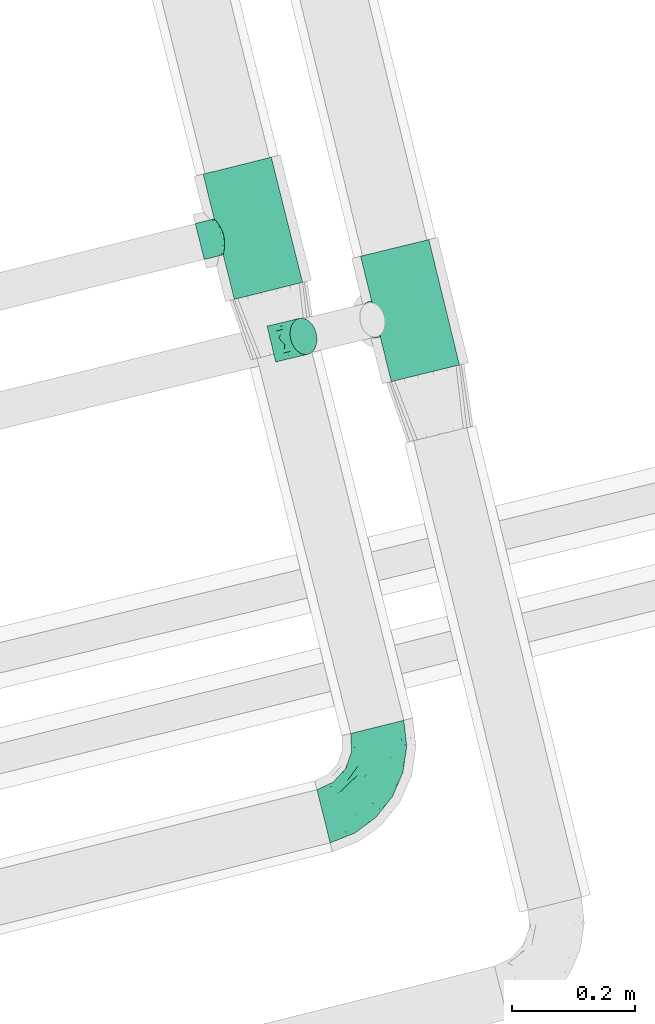
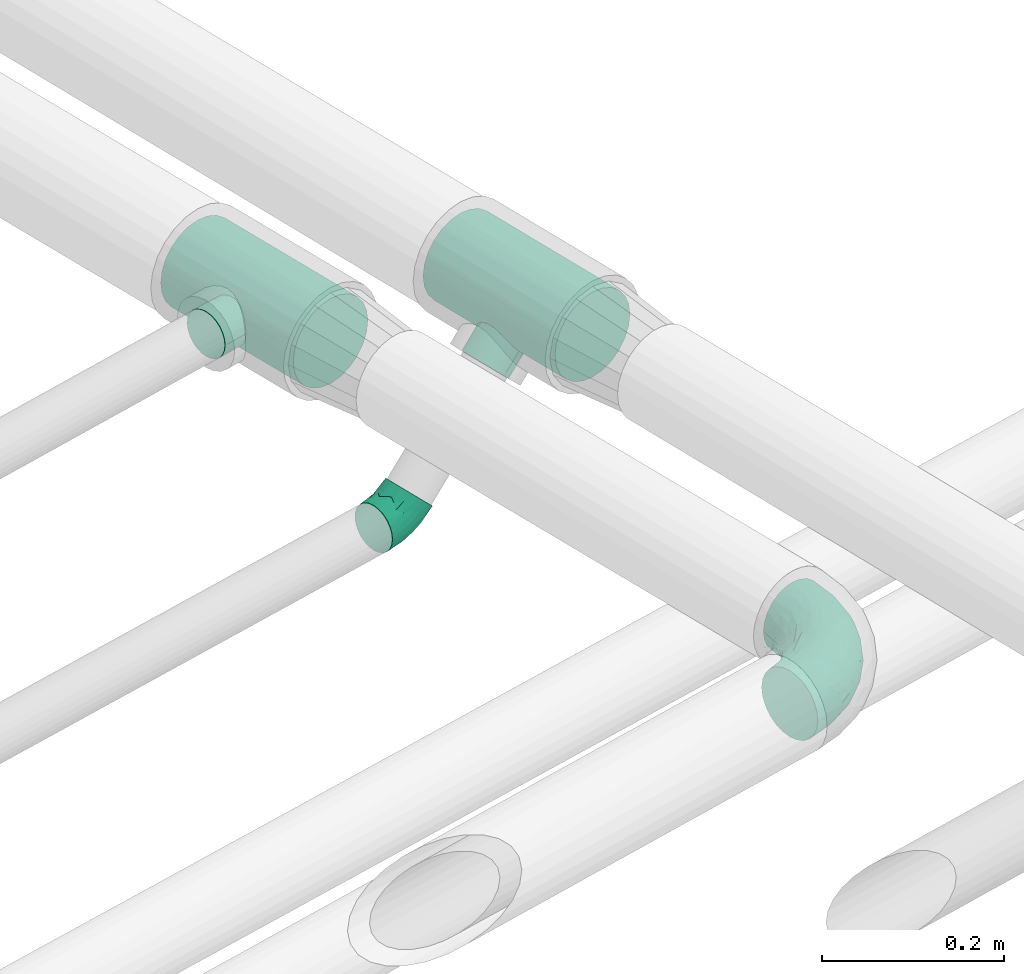
# One storey, part 83 of 93: 4 flow fittings.
"""IFC2X3 building model written with IfcOpenShell, lengths in millimetres."""

import ifcopenshell
import ifcopenshell.guid

model = None  # the IFC model being written
_history = None  # IfcOwnerHistory: only IFC2X3 demands one
_inside = {}  # id of a spatial element -> (the spatial element, [elements in it])
_under = {}  # id of a project, library or spatial element -> (it, [spatial elements below it])
_declared = {}  # id of a project -> (the project, [libraries it declares])
_typed = {}  # id of a type object -> (the type object, [elements of that type])
_made_of = {}  # id of a material, layer set ... -> (it, [elements and type objects made of it])


def new_model(schema):
    """Start an empty IFC model of exactly this schema.

    Asked for "IFC4X3", IfcOpenShell would pick the latest addendum, in which some entities
    have other attributes; the version numbers below select the first issue.
    IFC2X3 requires an IfcOwnerHistory on every rooted entity: one is made here for all.
    """
    global model, _history
    if schema == "IFC4X3":
        model = ifcopenshell.file(schema_version=(4, 3, 0, 0))
    else:
        model = ifcopenshell.file(schema=schema)
    _inside.clear()
    _under.clear()
    _declared.clear()
    _typed.clear()
    _made_of.clear()
    _history = None
    if model.schema == "IFC2X3":
        org = make("IfcOrganization", Name="unknown")
        user = make(
            "IfcPersonAndOrganization",
            ThePerson=make("IfcPerson", FamilyName="unknown"),
            TheOrganization=org,
        )
        app = make(
            "IfcApplication",
            ApplicationDeveloper=org,
            Version="unknown",
            ApplicationFullName="unknown",
            ApplicationIdentifier="unknown",
        )
        _history = make(
            "IfcOwnerHistory",
            OwningUser=user,
            OwningApplication=app,
            ChangeAction="ADDED",
            CreationDate=0,
        )
    return model


def make(cls, **values):
    """One entity of the class cls with the attributes given. An attribute that is None is left unset."""
    return model.create_entity(
        cls, **{name: value for name, value in values.items() if value is not None}
    )


def entity(cls, *values):
    """Any entity or typed value of the class cls, its attributes in the order of the schema. None: left unset."""
    e = model.create_entity(cls)
    for i, value in enumerate(values):
        if value is not None:
            e[i] = value
    return e


def rooted(cls, **values):
    """An entity with a GlobalId (a new one), such as an element, a storey or a relation."""
    return make(cls, GlobalId=ifcopenshell.guid.new(), OwnerHistory=_history, **values)


def si_unit(unit_type, name, prefix=None):
    """IfcSIUnit, for example si_unit("LENGTHUNIT", "METRE", prefix="MILLI")."""
    return make("IfcSIUnit", UnitType=unit_type, Prefix=prefix, Name=name)


def converted_unit(unit_type, name, factor, base, dimensions=None, offset=None):
    """IfcConversionBasedUnit, such as the inch: factor (a typed value) times the base unit."""
    return make(
        "IfcConversionBasedUnit"
        if offset is None
        else "IfcConversionBasedUnitWithOffset",
        ConversionOffset=offset,
        Dimensions=None
        if dimensions is None
        else entity("IfcDimensionalExponents", *dimensions),
        UnitType=unit_type,
        Name=name,
        ConversionFactor=make(
            "IfcMeasureWithUnit", ValueComponent=factor, UnitComponent=base
        ),
    )


def derived_unit(unit_type, elements):
    """IfcDerivedUnit: a product of units, each with its exponent."""
    return make(
        "IfcDerivedUnit",
        Elements=[
            make("IfcDerivedUnitElement", Unit=unit, Exponent=power)
            for unit, power in elements
        ],
        UnitType=unit_type,
    )


def assignment(units):
    """IfcUnitAssignment: the units of a project."""
    return None if units is None else make("IfcUnitAssignment", Units=units)


def point(xyz):
    """IfcCartesianPoint."""
    return None if xyz is None else make("IfcCartesianPoint", Coordinates=xyz)


def direction(xyz):
    """IfcDirection."""
    return None if xyz is None else make("IfcDirection", DirectionRatios=xyz)


def frame(location, z_axis=None, x_axis=None):
    """IfcAxis2Placement3D, a coordinate frame: its origin and axes. An axis left out is left unset."""
    return make(
        "IfcAxis2Placement3D",
        Location=point(location),
        Axis=direction(z_axis),
        RefDirection=direction(x_axis),
    )


def origin():
    """The frame at (0, 0, 0) with its axes left unset."""
    return frame((0.0, 0.0, 0.0))


def place(relative_to, where):
    """IfcLocalPlacement: puts the frame where relative to a parent placement (None: the world)."""
    return make(
        "IfcLocalPlacement", PlacementRelTo=relative_to, RelativePlacement=where
    )


def context(
    kind, dimensions, precision=None, world=None, true_north=None, identifier=None
):
    """IfcGeometricRepresentationContext, for example the 3D "Model" context."""
    return make(
        "IfcGeometricRepresentationContext",
        ContextIdentifier=identifier,
        ContextType=kind,
        CoordinateSpaceDimension=dimensions,
        Precision=precision,
        WorldCoordinateSystem=world,
        TrueNorth=true_north,
    )


def subcontext(parent, identifier, kind, view, scale=None):
    """IfcGeometricRepresentationSubContext, for example "Body" below "Model"."""
    return make(
        "IfcGeometricRepresentationSubContext",
        ContextIdentifier=identifier,
        ContextType=kind,
        ParentContext=parent,
        TargetScale=scale,
        TargetView=view,
    )


def project(units=None, contexts=None):
    """IfcProject with its units and contexts."""
    return rooted(
        "IfcProject",
        Name="project",
        RepresentationContexts=contexts,
        UnitsInContext=assignment(units),
    )


def spatial(cls, under=None, at=None, **own):
    """A site, building, storey or space (cls), placed at a placement, below another one or the project."""
    s = rooted(cls, ObjectPlacement=at, **own)
    if under is not None:
        _under.setdefault(under.id(), (under, []))[1].append(s)
    return s


def faces_of(points, faces, orient=None, outer=None):
    """IfcFace entities. A face is a list of loops; a loop is a list of indices into points, from 0.

    orient and outer hold one flag for each loop. By default every Orientation is true, the
    first loop of a face is its IfcFaceOuterBound and the others are IfcFaceBound.
    """
    made = []
    for i, loops in enumerate(faces):
        bounds = []
        for j, loop in enumerate(loops):
            is_outer = j == 0 if outer is None else outer[i][j]
            bounds.append(
                make(
                    "IfcFaceOuterBound" if is_outer else "IfcFaceBound",
                    Bound=make("IfcPolyLoop", Polygon=[points[k] for k in loop]),
                    Orientation=True if orient is None else orient[i][j],
                )
            )
        made.append(make("IfcFace", Bounds=bounds))
    return made


def faceted_brep(points, faces, orient=None, outer=None, voids=None):
    """IfcFacetedBrep: a solid bounded by flat faces; with voids (closed shells), ...WithVoids."""
    shared = [point(p) for p in points]
    hull = make("IfcClosedShell", CfsFaces=faces_of(shared, faces, orient, outer))
    if voids is None:
        return make("IfcFacetedBrep", Outer=hull)
    return make(
        "IfcFacetedBrepWithVoids",
        Outer=hull,
        Voids=[
            make(cls, CfsFaces=faces_of(shared, fs, o, b)) for cls, fs, o, b in voids
        ],
    )


def shape(context_of_items, identifier, shape_type, items):
    """IfcShapeRepresentation: the items that make up one representation, for example the "Body"."""
    return make(
        "IfcShapeRepresentation",
        ContextOfItems=context_of_items,
        RepresentationIdentifier=identifier,
        RepresentationType=shape_type,
        Items=items,
    )


def source(mapping_origin, context_of_items, identifier, shape_type, items):
    """IfcRepresentationMap: a shape defined once, which mapped items show again and again."""
    return make(
        "IfcRepresentationMap",
        MappingOrigin=mapping_origin,
        MappedRepresentation=shape(context_of_items, identifier, shape_type, items),
    )


def transform(
    local_origin,
    x_axis=None,
    y_axis=None,
    z_axis=None,
    scale=None,
    scale2=None,
    scale3=None,
    uniform=True,
):
    """IfcCartesianTransformationOperator3D, or its non-uniform kind. x_axis, y_axis, z_axis: its Axis1, 2, 3."""
    if uniform:
        return make(
            "IfcCartesianTransformationOperator3D",
            Axis1=direction(x_axis),
            Axis2=direction(y_axis),
            LocalOrigin=point(local_origin),
            Scale=scale,
            Axis3=direction(z_axis),
        )
    return make(
        "IfcCartesianTransformationOperator3DnonUniform",
        Axis1=direction(x_axis),
        Axis2=direction(y_axis),
        LocalOrigin=point(local_origin),
        Scale=scale,
        Axis3=direction(z_axis),
        Scale2=scale2,
        Scale3=scale3,
    )


def mapped(mapping_source, mapping_target):
    """IfcMappedItem: shows the shape of a source again, moved by a transform."""
    return make(
        "IfcMappedItem", MappingSource=mapping_source, MappingTarget=mapping_target
    )


def material(Name=None, Category=None):
    """IfcMaterial."""
    return make("IfcMaterial", Name=Name, Category=Category)


def made_of(thing, what):
    """Note that an element or type object is made of a material, layer set ...; save() writes the relation."""
    if what is not None:
        _made_of.setdefault(what.id(), (what, []))[1].append(thing)
    return thing


def type_object(cls, material=None, **own):
    """A type object (cls), such as IfcWallType, which elements share."""
    return made_of(rooted(cls, **own), material)


def type_shapes(of_type, sources):
    """Give a type object the sources (RepresentationMaps) that its elements show as mapped items."""
    of_type.RepresentationMaps = sources


def element(
    cls,
    number,
    at=None,
    inside=None,
    cuts=None,
    type_object=None,
    material=None,
    context=None,
    identifier="Body",
    shape_type=None,
    held_by="IfcProductDefinitionShape",
    body=None,
    shapes=None,
    **own,
):
    """One element of the class cls, such as IfcWall. Its Tag is "e" and its number.

    at: its placement. inside: the storey or other place that contains it. cuts: it is an
    opening in that element (IfcRelVoidsElement). A single representation is given by context,
    identifier, shape_type and body (its items); several are given by shapes. held_by: the class
    of the entity that holds the representations. save() writes the other relations.
    """
    e = rooted(cls, Tag="e%d" % number, ObjectPlacement=at, **own)
    if body is not None:
        shapes = [shape(context, identifier, shape_type, body)]
    if shapes is not None:
        e.Representation = make(held_by, Representations=shapes)
    if inside is not None:
        _inside.setdefault(inside.id(), (inside, []))[1].append(e)
    if cuts is not None:
        rooted(
            "IfcRelVoidsElement", RelatingBuildingElement=cuts, RelatedOpeningElement=e
        )
    if type_object is not None:
        _typed.setdefault(type_object.id(), (type_object, []))[1].append(e)
    return made_of(e, material)


def aggregate(whole, parts):
    """IfcRelAggregates: a whole, such as a stair, and the parts it consists of."""
    return rooted("IfcRelAggregates", RelatingObject=whole, RelatedObjects=parts)


def save(model, path):
    """Write the relations noted so far, then the file.

    IfcRelAggregates (storeys below a building ...), IfcRelContainedInSpatialStructure (elements
    in a storey), IfcRelDefinesByType, IfcRelAssociatesMaterial and IfcRelDeclares: one each for
    every whole, place, type object, material and project.
    """
    for whole, parts in _under.values():
        aggregate(whole, parts)
    for where, things in _inside.values():
        rooted(
            "IfcRelContainedInSpatialStructure",
            RelatedElements=things,
            RelatingStructure=where,
        )
    for kind, things in _typed.values():
        rooted("IfcRelDefinesByType", RelatedObjects=things, RelatingType=kind)
    for what, things in _made_of.values():
        rooted("IfcRelAssociatesMaterial", RelatedObjects=things, RelatingMaterial=what)
    for by, libraries in _declared.values():
        rooted("IfcRelDeclares", RelatingContext=by, RelatedDefinitions=libraries)
    model.write(path)


model = new_model("IFC2X3")

# Units and contexts
model_context = context("Model", 3, precision=0.01, world=origin(), true_north=direction((6.12303176911189e-17, 1.0)))
body_context = subcontext(model_context, "Body", "Model", "MODEL_VIEW")
ifc_project = project(units=[si_unit("LENGTHUNIT", "METRE", prefix="MILLI"), si_unit("AREAUNIT", "SQUARE_METRE"), si_unit("VOLUMEUNIT", "CUBIC_METRE"), converted_unit("PLANEANGLEUNIT", "DEGREE", entity("IfcRatioMeasure", 0.0174532925199433), si_unit("PLANEANGLEUNIT", "RADIAN"), dimensions=[0, 0, 0, 0, 0, 0, 0]), si_unit("MASSUNIT", "GRAM", prefix="KILO"), derived_unit("MASSDENSITYUNIT", [(si_unit("MASSUNIT", "GRAM", prefix="KILO"), 1), (si_unit("LENGTHUNIT", "METRE"), -3)]), derived_unit("MOMENTOFINERTIAUNIT", [(si_unit("LENGTHUNIT", "METRE"), 4)]), si_unit("TIMEUNIT", "SECOND"), si_unit("FREQUENCYUNIT", "HERTZ"), si_unit("THERMODYNAMICTEMPERATUREUNIT", "DEGREE_CELSIUS"), derived_unit("THERMALTRANSMITTANCEUNIT", [(si_unit("MASSUNIT", "GRAM", prefix="KILO"), 1), (si_unit("THERMODYNAMICTEMPERATUREUNIT", "KELVIN"), -1), (si_unit("TIMEUNIT", "SECOND"), -3)]), derived_unit("VOLUMETRICFLOWRATEUNIT", [(si_unit("LENGTHUNIT", "METRE"), 3), (si_unit("TIMEUNIT", "SECOND"), -1)]), derived_unit("MASSFLOWRATEUNIT", [(si_unit("MASSUNIT", "GRAM", prefix="KILO"), 1), (si_unit("TIMEUNIT", "SECOND"), -1)]), derived_unit("ROTATIONALFREQUENCYUNIT", [(si_unit("TIMEUNIT", "SECOND"), -1)]), si_unit("ELECTRICCURRENTUNIT", "AMPERE"), si_unit("ELECTRICVOLTAGEUNIT", "VOLT"), si_unit("POWERUNIT", "WATT"), si_unit("FORCEUNIT", "NEWTON", prefix="KILO"), si_unit("ILLUMINANCEUNIT", "LUX"), si_unit("LUMINOUSFLUXUNIT", "LUMEN"), si_unit("LUMINOUSINTENSITYUNIT", "CANDELA"), derived_unit("USERDEFINED", [(si_unit("MASSUNIT", "GRAM", prefix="KILO"), -1), (si_unit("LENGTHUNIT", "METRE"), -2), (si_unit("TIMEUNIT", "SECOND"), 3), (si_unit("LUMINOUSFLUXUNIT", "LUMEN"), 1)]), derived_unit("LINEARVELOCITYUNIT", [(si_unit("LENGTHUNIT", "METRE"), 1), (si_unit("TIMEUNIT", "SECOND"), -1)]), si_unit("PRESSUREUNIT", "PASCAL"), derived_unit("USERDEFINED", [(si_unit("LENGTHUNIT", "METRE"), -2), (si_unit("MASSUNIT", "GRAM", prefix="KILO"), 1), (si_unit("TIMEUNIT", "SECOND"), -2)]), derived_unit("LINEARFORCEUNIT", [(si_unit("MASSUNIT", "GRAM", prefix="KILO"), 1), (si_unit("LENGTHUNIT", "METRE"), 1), (si_unit("TIMEUNIT", "SECOND"), -2), (si_unit("LENGTHUNIT", "METRE"), -1)]), derived_unit("PLANARFORCEUNIT", [(si_unit("MASSUNIT", "GRAM", prefix="KILO"), 1), (si_unit("LENGTHUNIT", "METRE"), 1), (si_unit("TIMEUNIT", "SECOND"), -2), (si_unit("LENGTHUNIT", "METRE"), -2)])], contexts=[model_context])

# Site, building, storey
site_placement = place(None, origin())
site = spatial("IfcSite", under=ifc_project, at=site_placement, CompositionType="ELEMENT")
building_placement = place(site_placement, origin())
building = spatial("IfcBuilding", under=site, at=building_placement, CompositionType="ELEMENT")
storey_placement = place(building_placement, frame((0.0, 0.0, -4200.0)))
storey = spatial("IfcBuildingStorey", under=building, at=storey_placement, CompositionType="ELEMENT", Elevation=-4200.0)

# Flow fittings
ifc_material = material()
pipe_fitting_type_1 = type_object("IfcPipeFittingType", Name="ADSK_1", PredefinedType="NOTDEFINED", material=ifc_material)
shared_shape_1 = source(origin(), body_context, "Body", "Brep", [
    faceted_brep([(-105.0, 0.0, -57.15), (-105.0, -14.79, -55.2), (-105.0, -28.57, -49.49), (-105.0, -40.41, -40.41), (-105.0, -49.49, -28.58), (-105.0, -55.2, -14.79), (-105.0, -57.15, 0.0), (-105.0, -55.2, 14.79), (-105.0, -49.49, 28.57), (-105.0, -40.41, 40.41), (-105.0, -28.57, 49.49), (-105.0, -14.79, 55.2), (-105.0, 0.0, 57.15), (-105.0, 14.79, 55.2), (-105.0, 28.58, 49.49), (-105.0, 40.41, 40.41), (-105.0, 49.49, 28.57), (-105.0, 55.2, 14.79), (-105.0, 57.15, 0.0), (-105.0, 55.2, -14.79), (-105.0, 49.49, -28.58), (-105.0, 40.41, -40.41), (-105.0, 28.58, -49.49), (-105.0, 14.79, -55.2), (105.0, -28.57, -49.49), (105.0, -14.79, -55.2), (105.0, 0.0, -57.15), (105.0, 14.79, -55.2), (105.0, 28.58, -49.49), (105.0, 40.41, -40.41), (105.0, 49.49, -28.58), (105.0, 55.2, -14.79), (105.0, 57.15, 0.0), (105.0, 55.2, 14.79), (105.0, 49.49, 28.57), (105.0, 40.41, 40.41), (105.0, 28.58, 49.49), (105.0, 14.79, 55.2), (105.0, 0.0, 57.15), (105.0, -14.79, 55.2), (105.0, -28.57, 49.49), (105.0, -40.41, 40.41), (105.0, -49.49, 28.57), (105.0, -55.2, 14.79), (105.0, -57.15, 0.0), (105.0, -55.2, -14.79), (105.0, -49.49, -28.58), (105.0, -40.41, -40.41), (28.28, 56.18, 10.46), (30.15, 57.15, 0.0), (29.21, 56.67, 5.23), (23.04, 53.74, 19.44), (5.32, 48.84, 29.68), (15.17, 50.86, 26.06), (10.25, 49.85, 27.87), (-28.28, 56.19, 10.46), (-29.21, 56.67, 5.23), (-30.15, 57.15, 0.0), (-23.05, 53.74, 19.43), (-5.33, 48.84, 29.67), (-10.25, 49.85, 27.86), (-15.17, 50.87, 26.05), (0.0, 48.84, 29.68), (5.32, 48.84, -29.68), (10.25, 49.85, -27.87), (15.17, 50.86, -26.06), (23.04, 53.74, -19.44), (28.28, 56.18, -10.46), (29.21, 56.67, -5.23), (-15.17, 50.87, -26.05), (-10.25, 49.85, -27.86), (-5.33, 48.84, -29.67), (-23.05, 53.74, -19.43), (0.0, 48.84, -29.68), (-28.28, 56.19, -10.46), (-29.21, 56.67, -5.23), (15.08, 89.0, -26.11), (7.8, 89.0, -29.12), (0.0, 89.0, -30.15), (-7.8, 89.0, -29.12), (-15.07, 89.0, -26.11), (-21.32, 89.0, -21.32), (-26.11, 89.0, -15.08), (-29.12, 89.0, -7.8), (-30.15, 89.0, 0.0), (-29.12, 89.0, 7.8), (-26.11, 89.0, 15.07), (-21.32, 89.0, 21.32), (-15.07, 89.0, 26.11), (-7.8, 89.0, 29.12), (0.0, 89.0, 30.15), (7.8, 89.0, 29.12), (15.08, 89.0, 26.11), (21.32, 89.0, 21.32), (26.11, 89.0, 15.07), (29.12, 89.0, 7.8), (30.15, 89.0, 0.0), (29.12, 89.0, -7.8), (26.11, 89.0, -15.08), (21.32, 89.0, -21.32)], [[[0, 1, 2, 3, 4, 5, 6, 7, 8, 9, 10, 11, 12, 13, 14, 15, 16, 17, 18, 19, 20, 21, 22, 23]], [[24, 25, 26, 27, 28, 29, 30, 31, 32, 33, 34, 35, 36, 37, 38, 39, 40, 41, 42, 43, 44, 45, 46, 47]], [[48, 33, 32]], [[32, 49, 50, 48]], [[48, 51, 33]], [[52, 35, 34]], [[34, 51, 53]], [[34, 53, 54, 52]], [[52, 15, 35]], [[33, 51, 34]], [[18, 55, 56, 57]], [[55, 18, 17]], [[17, 58, 55]], [[16, 59, 60, 61]], [[58, 16, 61]], [[15, 59, 16]], [[17, 16, 58]], [[15, 52, 62, 59]], [[15, 14, 36, 35]], [[38, 37, 13, 12]], [[37, 36, 14, 13]], [[39, 38, 12, 11]], [[7, 43, 42, 8]], [[41, 40, 10, 9]], [[42, 41, 9, 8]], [[10, 40, 39, 11]], [[44, 43, 7, 6]], [[46, 45, 5, 4]], [[3, 47, 46, 4]], [[6, 5, 45, 44]], [[23, 27, 26, 0]], [[25, 24, 2, 1]], [[26, 25, 1, 0]], [[2, 24, 47, 3]], [[27, 23, 22, 28]], [[22, 21, 29, 28]], [[63, 30, 29]], [[30, 63, 64, 65]], [[65, 66, 30]], [[21, 63, 29]], [[67, 32, 31]], [[31, 66, 67]], [[32, 67, 68, 49]], [[30, 66, 31]], [[20, 69, 70, 71]], [[71, 21, 20]], [[20, 72, 69]], [[21, 71, 73, 63]], [[19, 74, 72]], [[19, 18, 74]], [[18, 57, 75, 74]], [[20, 19, 72]], [[76, 77, 78, 79, 80, 81, 82, 83, 84, 85, 86, 87, 88, 89, 90, 91, 92, 93, 94, 95, 96, 97, 98, 99]], [[84, 56, 85]], [[89, 59, 90]], [[89, 88, 60]], [[88, 61, 60]], [[91, 54, 92]], [[56, 55, 85]], [[49, 96, 50]], [[86, 85, 55]], [[84, 57, 56]], [[58, 86, 55]], [[87, 61, 88]], [[60, 59, 89]], [[58, 61, 87]], [[86, 58, 87]], [[62, 52, 90, 59]], [[54, 53, 92]], [[92, 53, 93]], [[95, 94, 48]], [[51, 94, 93]], [[91, 90, 52]], [[91, 52, 54]], [[51, 93, 53]], [[48, 94, 51]], [[95, 50, 96]], [[95, 48, 50]], [[96, 68, 97]], [[98, 66, 99]], [[77, 76, 64]], [[68, 67, 97]], [[97, 67, 98]], [[83, 74, 75]], [[76, 99, 65]], [[96, 49, 68]], [[66, 98, 67]], [[64, 63, 77]], [[99, 66, 65]], [[73, 71, 78, 63]], [[79, 70, 80]], [[77, 63, 78]], [[70, 69, 80]], [[57, 84, 75]], [[80, 69, 81]], [[83, 82, 74]], [[72, 82, 81]], [[79, 78, 71]], [[79, 71, 70]], [[72, 81, 69]], [[74, 82, 72]], [[83, 75, 84]], [[76, 65, 64]]]),
])
type_shapes(pipe_fitting_type_1, [shared_shape_1])
flow_fitting_1_placement = place(storey_placement, frame((-16166.62, 9838.45, 2500.56), z_axis=(0.686991971818694, 0.167457548819585, -0.707106781186547), x_axis=(0.237217705772626, -0.971456428815589, 0.000408632885787963)))
element("IfcFlowFitting", 1, at=flow_fitting_1_placement, inside=storey, type_object=pipe_fitting_type_1, material=ifc_material, Name="ADSK_1", ObjectType="ADSK_1", context=body_context, shape_type="MappedRepresentation", body=[
    mapped(shared_shape_1, transform((0.0, 0.0, 0.0), scale=1.0)),
])
pipe_fitting_type_2 = type_object("IfcPipeFittingType", Name="ADSK_1", PredefinedType="NOTDEFINED", material=ifc_material)
shared_shape_2 = source(origin(), body_context, "Body", "Brep", [
    faceted_brep([(-105.0, 28.57, -49.49), (-105.0, 14.79, -55.2), (-105.0, 0.0, -57.15), (-105.0, -14.79, -55.2), (-105.0, -28.58, -49.49), (-105.0, -40.41, -40.41), (-105.0, -49.49, -28.58), (-105.0, -55.2, -14.79), (-105.0, -57.15, 0.0), (-105.0, -55.2, 14.79), (-105.0, -49.49, 28.57), (-105.0, -40.41, 40.41), (-105.0, -28.58, 49.49), (-105.0, -14.79, 55.2), (-105.0, 0.0, 57.15), (-105.0, 14.79, 55.2), (-105.0, 28.57, 49.49), (-105.0, 40.41, 40.41), (-105.0, 49.49, 28.57), (-105.0, 55.2, 14.79), (-105.0, 57.15, 0.0), (-105.0, 55.2, -14.79), (-105.0, 49.49, -28.58), (-105.0, 40.41, -40.41), (105.0, 0.0, -57.15), (105.0, 14.79, -55.2), (105.0, 28.57, -49.49), (105.0, 40.41, -40.41), (105.0, 49.49, -28.58), (105.0, 55.2, -14.79), (105.0, 57.15, 0.0), (105.0, 55.2, 14.79), (105.0, 49.49, 28.57), (105.0, 40.41, 40.41), (105.0, 28.57, 49.49), (105.0, 14.79, 55.2), (105.0, 0.0, 57.15), (105.0, -14.79, 55.2), (105.0, -28.58, 49.49), (105.0, -40.41, 40.41), (105.0, -49.49, 28.57), (105.0, -55.2, 14.79), (105.0, -57.15, 0.0), (105.0, -55.2, -14.79), (105.0, -49.49, -28.58), (105.0, -40.41, -40.41), (105.0, -28.58, -49.49), (105.0, -14.79, -55.2), (28.28, -56.18, 10.46), (29.21, -56.67, 5.23), (30.15, -57.15, 0.0), (23.04, -53.74, 19.44), (5.32, -48.84, 29.68), (15.17, -50.86, 26.06), (10.25, -49.85, 27.87), (-30.15, -57.15, 0.0), (-29.21, -56.67, 5.23), (-28.28, -56.19, 10.46), (-23.05, -53.74, 19.43), (-15.17, -50.87, 26.05), (-10.25, -49.85, 27.86), (-5.33, -48.84, 29.67), (0.0, -48.84, 29.68), (5.32, -48.84, -29.68), (15.17, -50.86, -26.06), (10.25, -49.85, -27.87), (23.04, -53.74, -19.44), (28.28, -56.18, -10.46), (29.21, -56.67, -5.23), (-5.33, -48.84, -29.67), (-10.25, -49.85, -27.86), (-15.17, -50.87, -26.05), (-23.05, -53.74, -19.43), (0.0, -48.84, -29.68), (-28.28, -56.19, -10.46), (-29.21, -56.67, -5.23), (0.0, -89.0, -30.15), (7.8, -89.0, -29.12), (15.08, -89.0, -26.11), (21.32, -89.0, -21.32), (26.11, -89.0, -15.08), (29.12, -89.0, -7.8), (30.15, -89.0, 0.0), (29.12, -89.0, 7.8), (26.11, -89.0, 15.07), (21.32, -89.0, 21.32), (15.08, -89.0, 26.11), (7.8, -89.0, 29.12), (0.0, -89.0, 30.15), (-7.8, -89.0, 29.12), (-15.07, -89.0, 26.11), (-21.32, -89.0, 21.32), (-26.11, -89.0, 15.07), (-29.12, -89.0, 7.8), (-30.15, -89.0, 0.0), (-29.12, -89.0, -7.8), (-26.11, -89.0, -15.08), (-21.32, -89.0, -21.32), (-15.07, -89.0, -26.11), (-7.8, -89.0, -29.12)], [[[0, 1, 2, 3, 4, 5, 6, 7, 8, 9, 10, 11, 12, 13, 14, 15, 16, 17, 18, 19, 20, 21, 22, 23]], [[24, 25, 26, 27, 28, 29, 30, 31, 32, 33, 34, 35, 36, 37, 38, 39, 40, 41, 42, 43, 44, 45, 46, 47]], [[42, 41, 48]], [[42, 48, 49, 50]], [[41, 51, 48]], [[40, 39, 52]], [[53, 51, 40]], [[40, 52, 54, 53]], [[39, 11, 52]], [[40, 51, 41]], [[8, 55, 56, 57]], [[9, 8, 57]], [[57, 58, 9]], [[10, 59, 60, 61]], [[59, 10, 58]], [[10, 61, 11]], [[58, 10, 9]], [[11, 61, 62, 52]], [[39, 38, 12, 11]], [[14, 13, 37, 36]], [[13, 12, 38, 37]], [[15, 14, 36, 35]], [[32, 31, 19, 18]], [[17, 16, 34, 33]], [[18, 17, 33, 32]], [[35, 34, 16, 15]], [[20, 19, 31, 30]], [[21, 29, 28, 22]], [[28, 27, 23, 22]], [[30, 29, 21, 20]], [[24, 47, 3, 2]], [[1, 0, 26, 25]], [[2, 1, 25, 24]], [[27, 26, 0, 23]], [[46, 4, 3, 47]], [[46, 45, 5, 4]], [[45, 44, 63]], [[44, 64, 65, 63]], [[44, 66, 64]], [[45, 63, 5]], [[43, 42, 67]], [[67, 66, 43]], [[42, 50, 68, 67]], [[43, 66, 44]], [[6, 69, 70, 71]], [[6, 5, 69]], [[71, 72, 6]], [[5, 63, 73, 69]], [[72, 74, 7]], [[74, 8, 7]], [[8, 74, 75, 55]], [[72, 7, 6]], [[76, 77, 78, 79, 80, 81, 82, 83, 84, 85, 86, 87, 88, 89, 90, 91, 92, 93, 94, 95, 96, 97, 98, 99]], [[93, 56, 94]], [[88, 61, 89]], [[60, 90, 89]], [[60, 59, 90]], [[86, 54, 87]], [[93, 57, 56]], [[49, 82, 50]], [[57, 93, 92]], [[56, 55, 94]], [[57, 92, 58]], [[90, 59, 91]], [[89, 61, 60]], [[91, 59, 58]], [[91, 58, 92]], [[88, 52, 62, 61]], [[86, 53, 54]], [[85, 53, 86]], [[48, 84, 83]], [[85, 84, 51]], [[52, 88, 87]], [[54, 52, 87]], [[53, 85, 51]], [[51, 84, 48]], [[82, 49, 83]], [[49, 48, 83]], [[81, 68, 82]], [[79, 66, 80]], [[65, 78, 77]], [[81, 67, 68]], [[80, 67, 81]], [[75, 74, 95]], [[64, 79, 78]], [[68, 50, 82]], [[67, 80, 66]], [[77, 63, 65]], [[64, 66, 79]], [[76, 69, 73, 63]], [[98, 70, 99]], [[76, 63, 77]], [[98, 71, 70]], [[75, 94, 55]], [[97, 71, 98]], [[74, 96, 95]], [[97, 96, 72]], [[69, 76, 99]], [[70, 69, 99]], [[71, 97, 72]], [[72, 96, 74]], [[94, 75, 95]], [[65, 64, 78]]]),
])
type_shapes(pipe_fitting_type_2, [shared_shape_2])
flow_fitting_2_placement = place(storey_placement, frame((-16422.36, 9972.38, 2500.0), z_axis=(0.0, 0.0, -1.0), x_axis=(-0.242135671523185, 0.970242400937011, 0.0)))
element("IfcFlowFitting", 2, at=flow_fitting_2_placement, inside=storey, type_object=pipe_fitting_type_2, material=ifc_material, Name="ADSK_1", ObjectType="ADSK_1", context=body_context, shape_type="MappedRepresentation", body=[
    mapped(shared_shape_2, transform((0.0, 0.0, 0.0), scale=1.0)),
])
pipe_fitting_type_3 = type_object("IfcPipeFittingType", Name="ADSK_1", PredefinedType="NOTDEFINED", material=ifc_material)
shared_shape_3 = source(origin(), body_context, "Body", "Brep", [
    faceted_brep([(-31.48, 15.07, -26.11), (-31.48, 7.8, -29.12), (-31.48, 0.0, -30.15), (-31.48, -7.8, -29.12), (-31.48, -15.08, -26.11), (-31.48, -21.32, -21.32), (-31.48, -26.11, -15.08), (-31.48, -29.12, -7.8), (-31.48, -30.15, 0.0), (-31.48, -29.12, 7.8), (-31.48, -26.11, 15.07), (-31.48, -21.32, 21.32), (-31.48, -15.08, 26.11), (-31.48, -7.8, 29.12), (-31.48, 0.0, 30.15), (-31.48, 7.8, 29.12), (-31.48, 15.07, 26.11), (-31.48, 21.32, 21.32), (-31.48, 26.11, 15.07), (-31.48, 29.12, 7.8), (-31.48, 30.15, 0.0), (-31.48, 29.12, -7.8), (-31.48, 26.11, -15.08), (-31.48, 21.32, -21.32), (22.26, 22.26, -30.15), (16.74, 27.78, -29.12), (11.6, 32.92, -26.11), (7.18, 37.33, -21.32), (3.8, 40.72, -15.08), (1.67, 42.85, -7.8), (0.94, 43.58, 0.0), (1.67, 42.85, 7.8), (3.8, 40.72, 15.07), (7.18, 37.33, 21.32), (11.6, 32.92, 26.11), (16.74, 27.78, 29.12), (22.26, 22.26, 30.15), (27.78, 16.74, 29.12), (32.92, 11.6, 26.11), (37.33, 7.18, 21.32), (40.72, 3.8, 15.07), (42.85, 1.67, 7.8), (43.58, 0.94, 0.0), (42.85, 1.67, -7.8), (40.72, 3.8, -15.08), (37.33, 7.18, -21.32), (32.92, 11.6, -26.11), (27.78, 16.74, -29.12), (-13.23, -22.65, 17.82), (-7.91, -25.48, 10.72), (7.08, -17.1, 17.19), (-16.58, -28.19, 0.0), (-4.01, -26.53, 0.0), (-10.94, -27.67, 5.27), (-9.15, -16.34, 23.41), (25.37, -6.66, 17.82), (4.36, -10.54, 24.43), (-15.78, -10.67, 27.63), (10.17, 16.59, 29.95), (-11.5, -2.18, 29.78), (-3.47, 8.38, 30.02), (-18.92, 4.53, 29.95), (18.03, -5.08, 23.41), (18.7, 3.61, 27.63), (-14.12, 13.22, 28.12), (-9.12, 22.01, 24.5), (9.1, -19.5, 11.76), (8.92, -21.54, 5.84), (-15.89, 25.86, 18.9), (-12.93, 31.22, 12.3), (27.3, -11.83, 5.27), (31.65, -8.21, 0.0), (-10.3, 34.59, 6.29), (9.68, 6.59, 29.78), (2.47, -5.97, 27.34), (-3.1, 31.98, 18.74), (23.61, -12.42, 10.72), (2.38, 20.45, 28.09), (-13.93, 33.64, 0.0), (8.79, -21.23, 0.0), (21.59, -15.93, 0.0), (-11.5, -2.18, -29.78), (-10.94, -27.67, -5.27), (8.9, -21.5, -6.08), (0.63, 19.33, -28.12), (-18.92, 4.53, -29.95), (-17.18, 31.74, -6.29), (-12.93, 31.22, -12.3), (18.03, -5.08, -23.41), (-9.12, 22.01, -24.5), (23.61, -12.42, -10.72), (-20.42, 24.8, -18.74), (9.68, 6.59, -29.78), (-16.15, 12.78, -28.09), (-7.91, -25.48, -10.72), (25.37, -6.66, -17.82), (-13.23, -22.65, -17.82), (7.08, -17.1, -17.19), (6.98, -20.32, -11.87), (-9.15, -16.34, -23.41), (4.36, -10.54, -24.43), (2.47, -5.97, -27.34), (18.7, 3.61, -27.63), (-15.78, -10.67, -27.63), (-7.05, 29.52, -18.9), (27.3, -11.83, -5.27), (10.17, 16.59, -29.95), (-3.47, 8.38, -30.02)], [[[0, 1, 2, 3, 4, 5, 6, 7, 8, 9, 10, 11, 12, 13, 14, 15, 16, 17, 18, 19, 20, 21, 22, 23]], [[24, 25, 26, 27, 28, 29, 30, 31, 32, 33, 34, 35, 36, 37, 38, 39, 40, 41, 42, 43, 44, 45, 46, 47]], [[48, 49, 50]], [[51, 52, 53]], [[12, 11, 54]], [[40, 39, 55]], [[54, 56, 57]], [[48, 11, 10]], [[36, 35, 58]], [[13, 12, 57]], [[59, 60, 61]], [[14, 13, 59]], [[62, 55, 39]], [[38, 37, 63]], [[61, 15, 14]], [[16, 64, 65]], [[9, 51, 53]], [[34, 33, 65]], [[66, 49, 67]], [[65, 17, 16]], [[18, 17, 68]], [[18, 68, 69]], [[19, 18, 69]], [[41, 70, 71]], [[72, 20, 19]], [[52, 67, 53]], [[49, 53, 67]], [[16, 15, 64]], [[36, 58, 73]], [[39, 38, 62]], [[74, 73, 59]], [[73, 37, 36]], [[75, 65, 33]], [[76, 40, 55]], [[60, 58, 77]], [[62, 38, 63]], [[17, 65, 68]], [[70, 41, 76]], [[49, 48, 10]], [[61, 64, 15]], [[56, 50, 62]], [[19, 69, 72]], [[10, 9, 49]], [[78, 72, 30]], [[48, 54, 11]], [[31, 72, 69]], [[74, 63, 73]], [[69, 68, 75]], [[55, 62, 50]], [[32, 75, 33]], [[57, 59, 13]], [[35, 34, 77]], [[77, 65, 64]], [[56, 74, 57]], [[60, 59, 73]], [[76, 41, 40]], [[54, 48, 50]], [[32, 31, 69]], [[76, 55, 50]], [[65, 77, 34]], [[60, 77, 64]], [[54, 57, 12]], [[59, 57, 74]], [[73, 63, 37]], [[63, 74, 56]], [[9, 8, 51]], [[67, 52, 79, 80]], [[9, 53, 49]], [[70, 67, 80]], [[67, 76, 66]], [[71, 70, 80]], [[71, 42, 41]], [[67, 70, 76]], [[59, 61, 14]], [[64, 61, 60]], [[77, 58, 35]], [[73, 58, 60]], [[69, 75, 32]], [[65, 75, 68]], [[30, 72, 31]], [[72, 78, 20]], [[50, 56, 54]], [[63, 56, 62]], [[76, 50, 66]], [[49, 66, 50]], [[3, 2, 81]], [[52, 82, 83]], [[26, 25, 84]], [[2, 1, 85]], [[21, 86, 87]], [[46, 45, 88]], [[89, 0, 23]], [[44, 43, 90]], [[22, 91, 23]], [[24, 47, 92]], [[29, 28, 87]], [[1, 0, 93]], [[82, 7, 94]], [[90, 95, 44]], [[96, 97, 98]], [[96, 94, 6]], [[5, 4, 99]], [[100, 101, 102]], [[7, 6, 94]], [[5, 96, 6]], [[103, 4, 3]], [[91, 89, 23]], [[99, 96, 5]], [[28, 27, 104]], [[20, 78, 86]], [[27, 89, 104]], [[30, 29, 86]], [[100, 97, 99]], [[89, 84, 93]], [[87, 22, 21]], [[27, 26, 89]], [[103, 99, 4]], [[84, 89, 26]], [[104, 91, 87]], [[85, 81, 2]], [[104, 87, 28]], [[43, 71, 105]], [[106, 25, 24]], [[102, 47, 46]], [[7, 82, 51]], [[44, 95, 45]], [[102, 88, 100]], [[95, 88, 45]], [[107, 106, 92]], [[97, 95, 90]], [[107, 92, 81]], [[105, 71, 80]], [[102, 92, 47]], [[101, 103, 81]], [[82, 94, 83]], [[101, 81, 92]], [[98, 90, 83]], [[106, 84, 25]], [[29, 87, 86]], [[107, 85, 93]], [[96, 99, 97]], [[88, 95, 97]], [[89, 93, 0]], [[107, 93, 84]], [[81, 103, 3]], [[103, 101, 100]], [[88, 102, 46]], [[92, 102, 101]], [[51, 82, 52]], [[51, 8, 7]], [[98, 83, 94]], [[105, 83, 90]], [[83, 80, 79, 52]], [[43, 42, 71]], [[83, 105, 80]], [[43, 105, 90]], [[93, 85, 1]], [[81, 85, 107]], [[92, 106, 24]], [[84, 106, 107]], [[87, 91, 22]], [[89, 91, 104]], [[20, 86, 21]], [[86, 78, 30]], [[97, 100, 88]], [[103, 100, 99]], [[96, 98, 94]], [[90, 98, 97]]]),
])
type_shapes(pipe_fitting_type_3, [shared_shape_3])
flow_fitting_3_placement = place(storey_placement, frame((-16361.57, 9791.34, 2300.0), z_axis=(0.233655717903208, -0.972319394793263, 0.0), x_axis=(0.972319394793263, 0.233655717903208, 0.0)))
element("IfcFlowFitting", 3, at=flow_fitting_3_placement, inside=storey, type_object=pipe_fitting_type_3, material=ifc_material, Name="ADSK_1", ObjectType="ADSK_1", context=body_context, shape_type="MappedRepresentation", body=[
    mapped(shared_shape_3, transform((0.0, 0.0, 0.0), scale=1.0)),
])
pipe_fitting_type_4 = type_object("IfcPipeFittingType", Name="ADSK_2", PredefinedType="NOTDEFINED", material=ifc_material)
shared_shape_4 = source(origin(), body_context, "Body", "Brep", [
    faceted_brep([(-120.03, 22.25, -38.54), (-120.03, 11.52, -42.98), (-120.03, 0.0, -44.5), (-120.03, -11.52, -42.98), (-120.03, -22.25, -38.54), (-120.03, -31.47, -31.47), (-120.03, -38.54, -22.25), (-120.03, -42.98, -11.52), (-120.03, -44.5, 0.0), (-120.03, -42.98, 11.52), (-120.03, -38.54, 22.25), (-120.03, -31.47, 31.47), (-120.03, -22.25, 38.54), (-120.03, -11.52, 42.98), (-120.03, 0.0, 44.5), (-120.03, 11.52, 42.98), (-120.03, 22.25, 38.54), (-120.03, 31.47, 31.47), (-120.03, 38.54, 22.25), (-120.03, 42.98, 11.52), (-120.03, 44.5, 0.0), (-120.03, 42.98, -11.52), (-120.03, 38.54, -22.25), (-120.03, 31.47, -31.47), (-43.01, 120.02, -11.52), (-44.53, 120.02, 0.0), (-43.01, 120.02, 11.52), (-38.56, 120.02, 22.25), (-31.49, 120.02, 31.47), (-22.28, 120.02, 38.54), (-11.54, 120.02, 42.98), (-0.03, 120.03, 44.5), (11.49, 120.03, 42.98), (22.22, 120.03, 38.54), (31.44, 120.03, 31.47), (38.51, 120.03, 22.25), (42.96, 120.04, 11.52), (44.47, 120.04, 0.0), (42.96, 120.04, -11.52), (38.51, 120.03, -22.25), (31.44, 120.03, -31.47), (22.22, 120.03, -38.54), (11.49, 120.03, -42.98), (-0.03, 120.03, -44.5), (-11.54, 120.02, -42.98), (-22.28, 120.02, -38.54), (-31.49, 120.02, -31.47), (-38.56, 120.02, -22.25), (-20.53, 85.68, 41.98), (-29.33, 93.57, 36.45), (-98.03, -41.6, 0.0), (-80.95, -37.22, 14.68), (-66.7, -9.63, 39.67), (-84.61, -24.55, 33.9), (-50.37, -12.87, 32.85), (-77.44, -38.89, 0.0), (-22.02, -9.61, 13.22), (-37.77, -22.46, 0.0), (-20.73, -9.38, 0.0), (-89.21, -33.47, 25.4), (12.86, 50.38, 32.85), (24.54, 84.62, 33.9), (9.62, 66.7, 39.67), (-49.57, -27.06, 11.21), (-28.7, -9.99, 21.67), (-52.03, -22.41, 23.47), (-95.55, -16.28, 40.49), (-86.04, -3.42, 43.77), (22.4, 52.04, 23.47), (9.03, 21.39, 13.44), (26.49, 49.4, 12.73), (33.45, 89.22, 25.4), (37.21, 80.96, 14.68), (16.26, 95.55, 40.49), (3.4, 86.04, 43.77), (-7.85, 52.63, 43.16), (-84.41, 31.88, 36.84), (-30.54, 34.28, 44.33), (-21.99, 28.57, 42.22), (-93.59, 38.23, 28.63), (-65.06, 31.74, 41.51), (-92.01, 19.0, 41.83), (-34.05, 70.26, 39.41), (-96.38, 44.0, 18.64), (-98.51, 46.74, 8.65), (-76.52, 56.97, 9.76), (-4.98, 4.48, 11.33), (-7.18, 6.19, 18.93), (-56.64, 75.94, 12.18), (-66.63, 66.62, 0.0), (-92.14, 7.25, 44.33), (-7.25, 92.68, 44.32), (30.66, 57.61, 0.0), (-44.47, 94.82, 18.75), (-36.42, 102.0, 28.14), (-46.85, 97.46, 9.69), (-38.05, 47.62, 43.21), (-24.72, 65.71, 43.29), (41.58, 98.04, 0.0), (-54.13, 72.8, 21.53), (-47.98, 9.76, 42.93), (-18.67, 18.66, 37.89), (-91.13, 50.25, 0.0), (-50.27, 91.12, 0.0), (-57.61, -30.67, 0.0), (-44.18, 67.2, 34.92), (-55.17, 62.17, 29.74), (-68.12, 47.21, 32.31), (-51.11, 51.1, 38.36), (-16.7, 62.63, 44.46), (-58.29, 18.84, 44.48), (-71.58, 55.71, 20.5), (-43.15, 80.05, 29.45), (-37.24, 0.89, 36.78), (-18.15, 10.24, 33.09), (5.49, 28.09, 26.73), (-3.69, 3.69, 0.0), (9.38, 20.73, 0.0), (-2.59, 28.0, 33.59), (-2.4, 41.24, 38.93), (-16.13, 4.54, 27.07), (38.88, 77.45, 0.0), (22.45, 37.77, 0.0), (-92.68, 7.23, -44.32), (-22.02, -9.61, -13.22), (-49.83, -26.65, -12.91), (-28.7, -9.99, -21.67), (-62.63, 16.69, -44.46), (-65.06, 31.74, -41.51), (-38.9, 47.27, -43.11), (-56.64, 75.94, -12.18), (-93.59, 38.23, -28.63), (-84.41, 31.88, -36.84), (16.26, 95.55, -40.49), (3.4, 86.04, -43.77), (-98.51, 46.74, -8.65), (-44.47, 94.82, -18.75), (-54.13, 72.8, -21.53), (-76.52, 56.97, -9.76), (24.54, 84.62, -33.9), (9.62, 66.7, -39.67), (-96.38, 44.0, -18.64), (-29.42, 93.18, -36.47), (-92.01, 19.0, -41.83), (-80.95, -37.22, -14.68), (-52.63, 7.84, -43.16), (-86.04, -3.42, -43.77), (-89.21, -33.47, -25.4), (-52.03, -22.41, -23.47), (-50.37, -12.87, -32.85), (-84.61, -24.55, -33.9), (-66.7, -9.63, -39.67), (-95.55, -16.28, -40.49), (-68.12, 47.21, -32.31), (-35.83, 11.1, -40.85), (-19.63, 28.54, -41.6), (-18.67, 18.66, -37.89), (-4.98, 4.49, -11.34), (9.03, 21.39, -13.44), (-34.29, 30.53, -44.33), (-9.77, 47.97, -42.93), (-2.59, 28.0, -33.59), (-18.15, 10.24, -33.09), (-46.85, 97.46, -9.69), (12.86, 50.38, -32.85), (26.79, 49.15, -11.4), (-7.36, 92.06, -44.33), (-21.04, 83.88, -42.03), (-44.62, 66.83, -34.8), (-55.48, 62.19, -29.47), (37.21, 80.96, -14.68), (33.45, 89.22, -25.4), (-34.41, 70.13, -39.28), (-25.06, 64.42, -43.37), (-18.85, 58.28, -44.48), (22.4, 52.04, -23.47), (-36.42, 102.0, -28.14), (-51.11, 51.1, -38.36), (-43.15, 80.05, -29.45), (-71.58, 55.71, -20.5), (-7.17, 6.2, -18.94), (5.49, 28.09, -26.73), (-37.24, 0.89, -36.78), (-2.4, 41.24, -38.93), (-16.13, 4.54, -27.07)], [[[0, 1, 2, 3, 4, 5, 6, 7, 8, 9, 10, 11, 12, 13, 14, 15, 16, 17, 18, 19, 20, 21, 22, 23]], [[24, 25, 26, 27, 28, 29, 30, 31, 32, 33, 34, 35, 36, 37, 38, 39, 40, 41, 42, 43, 44, 45, 46, 47]], [[48, 29, 49]], [[50, 51, 9]], [[52, 53, 54]], [[9, 51, 10]], [[55, 51, 50]], [[56, 57, 58]], [[51, 59, 10]], [[60, 61, 62]], [[63, 64, 65]], [[13, 12, 66]], [[67, 14, 13]], [[68, 69, 70]], [[71, 68, 72]], [[33, 73, 61]], [[74, 75, 62]], [[17, 16, 76]], [[77, 78, 75]], [[79, 18, 17]], [[80, 76, 81]], [[30, 29, 48]], [[49, 82, 48]], [[18, 83, 19]], [[16, 81, 76]], [[20, 19, 84]], [[85, 84, 83]], [[56, 86, 87]], [[85, 88, 89]], [[32, 31, 74]], [[90, 14, 67]], [[79, 17, 76]], [[63, 65, 51]], [[13, 66, 67]], [[61, 34, 33]], [[91, 74, 31]], [[70, 92, 72]], [[93, 94, 27]], [[95, 88, 93]], [[62, 73, 74]], [[82, 96, 97]], [[35, 72, 36]], [[72, 68, 70]], [[71, 72, 35]], [[29, 28, 49]], [[72, 98, 36]], [[99, 93, 88]], [[71, 34, 61]], [[78, 100, 101]], [[85, 89, 102]], [[53, 52, 66]], [[103, 95, 25]], [[12, 11, 53]], [[103, 89, 88]], [[104, 57, 63]], [[91, 48, 97]], [[93, 27, 26]], [[28, 27, 94]], [[16, 15, 81]], [[105, 106, 107]], [[76, 107, 79]], [[30, 91, 31]], [[80, 96, 108]], [[26, 95, 93]], [[65, 53, 59]], [[73, 33, 32]], [[75, 74, 109]], [[61, 60, 68]], [[11, 10, 59]], [[54, 53, 65]], [[100, 67, 52]], [[110, 81, 90]], [[15, 14, 90]], [[76, 80, 108]], [[107, 76, 108]], [[83, 79, 111]], [[94, 49, 28]], [[82, 105, 108]], [[84, 85, 102]], [[111, 88, 85]], [[99, 88, 111]], [[94, 93, 112]], [[48, 91, 30]], [[74, 91, 109]], [[69, 87, 86]], [[113, 54, 114]], [[64, 56, 87]], [[60, 115, 68]], [[116, 117, 86]], [[69, 68, 115]], [[79, 83, 18]], [[85, 83, 111]], [[81, 110, 80]], [[110, 77, 96]], [[110, 96, 80]], [[97, 96, 109]], [[107, 108, 105]], [[111, 79, 107]], [[77, 75, 109]], [[118, 119, 101]], [[96, 77, 109]], [[77, 110, 100]], [[67, 100, 110]], [[100, 52, 113]], [[60, 119, 118]], [[118, 120, 115]], [[64, 54, 65]], [[114, 120, 118]], [[118, 115, 60]], [[115, 120, 87]], [[74, 73, 32]], [[61, 73, 62]], [[53, 66, 12]], [[67, 66, 52]], [[110, 90, 67]], [[15, 90, 81]], [[105, 49, 112]], [[96, 82, 108]], [[119, 60, 62]], [[118, 101, 114]], [[62, 75, 119]], [[78, 119, 75]], [[49, 105, 82]], [[105, 112, 106]], [[99, 112, 93]], [[111, 107, 106]], [[113, 114, 101]], [[54, 120, 114]], [[100, 113, 101]], [[52, 54, 113]], [[20, 84, 102]], [[83, 84, 19]], [[111, 106, 99]], [[112, 99, 106]], [[100, 78, 77]], [[119, 78, 101]], [[34, 71, 35]], [[68, 71, 61]], [[65, 59, 51]], [[11, 59, 53]], [[25, 95, 26]], [[103, 88, 95]], [[9, 8, 50]], [[98, 72, 121]], [[98, 37, 36]], [[49, 94, 112]], [[56, 63, 57]], [[51, 55, 104]], [[92, 121, 72]], [[86, 58, 116]], [[54, 64, 120]], [[115, 87, 69]], [[120, 64, 87]], [[58, 86, 56]], [[86, 117, 69]], [[91, 97, 109]], [[122, 69, 117]], [[82, 97, 48]], [[63, 56, 64]], [[104, 63, 51]], [[69, 122, 70]], [[92, 70, 122]], [[123, 2, 1]], [[124, 125, 126]], [[127, 128, 129]], [[103, 130, 89]], [[23, 131, 132]], [[42, 133, 134]], [[102, 135, 20]], [[130, 136, 137]], [[102, 138, 135]], [[139, 140, 133]], [[22, 21, 141]], [[46, 45, 142]], [[41, 40, 139]], [[0, 143, 1]], [[6, 144, 7]], [[145, 146, 127]], [[144, 50, 7]], [[147, 148, 144]], [[144, 6, 147]], [[149, 150, 151]], [[4, 3, 152]], [[23, 22, 131]], [[132, 131, 153]], [[38, 37, 98]], [[125, 104, 144]], [[154, 155, 156]], [[146, 151, 152]], [[4, 150, 5]], [[123, 146, 2]], [[157, 158, 117]], [[130, 138, 89]], [[24, 47, 136]], [[159, 160, 155]], [[161, 162, 156]], [[89, 138, 102]], [[163, 25, 24]], [[164, 140, 139]], [[163, 136, 130]], [[23, 132, 0]], [[158, 165, 122]], [[44, 43, 166]], [[0, 132, 143]], [[4, 152, 150]], [[142, 45, 167]], [[3, 2, 146]], [[167, 45, 44]], [[133, 42, 41]], [[168, 153, 169]], [[146, 145, 151]], [[149, 126, 148]], [[39, 170, 171]], [[43, 42, 134]], [[170, 39, 38]], [[144, 148, 125]], [[170, 98, 121]], [[168, 142, 172]], [[129, 173, 174]], [[98, 170, 38]], [[147, 5, 150]], [[157, 58, 124]], [[92, 122, 165]], [[134, 166, 43]], [[175, 139, 171]], [[47, 46, 176]], [[24, 136, 163]], [[132, 128, 143]], [[40, 39, 171]], [[164, 139, 175]], [[160, 134, 140]], [[174, 173, 166]], [[141, 131, 22]], [[132, 153, 177]], [[128, 132, 177]], [[123, 143, 127]], [[172, 142, 167]], [[176, 142, 178]], [[130, 179, 138]], [[138, 179, 141]], [[176, 136, 47]], [[130, 137, 179]], [[174, 166, 134]], [[167, 44, 166]], [[143, 123, 1]], [[146, 123, 127]], [[150, 149, 148]], [[157, 124, 180]], [[181, 161, 164]], [[181, 158, 180]], [[124, 126, 180]], [[170, 165, 175]], [[141, 21, 135]], [[131, 141, 179]], [[131, 179, 153]], [[179, 137, 169]], [[129, 128, 177]], [[127, 143, 128]], [[129, 177, 172]], [[129, 174, 159]], [[159, 145, 127]], [[182, 154, 156]], [[129, 159, 127]], [[159, 174, 160]], [[134, 160, 174]], [[140, 164, 183]], [[162, 182, 156]], [[126, 149, 184]], [[181, 164, 175]], [[164, 161, 183]], [[158, 181, 175]], [[184, 162, 161]], [[146, 152, 3]], [[150, 152, 151]], [[139, 133, 41]], [[134, 133, 140]], [[184, 161, 181]], [[161, 156, 183]], [[155, 183, 156]], [[160, 140, 183]], [[184, 149, 162]], [[182, 162, 149]], [[149, 151, 182]], [[154, 151, 145]], [[151, 154, 182]], [[159, 154, 145]], [[159, 155, 154]], [[183, 155, 160]], [[141, 135, 138]], [[20, 135, 21]], [[136, 178, 137]], [[169, 178, 168]], [[172, 167, 173]], [[168, 172, 177]], [[153, 168, 177]], [[142, 168, 178]], [[179, 169, 153]], [[137, 178, 169]], [[5, 147, 6]], [[148, 147, 150]], [[175, 171, 170]], [[40, 171, 139]], [[130, 103, 163]], [[25, 163, 103]], [[50, 144, 55]], [[50, 8, 7]], [[142, 176, 46]], [[136, 176, 178]], [[126, 125, 148]], [[104, 55, 144]], [[170, 121, 92]], [[57, 124, 58]], [[180, 126, 184]], [[181, 180, 184]], [[180, 158, 157]], [[158, 122, 117]], [[58, 157, 116]], [[172, 173, 129]], [[116, 157, 117]], [[166, 173, 167]], [[124, 57, 125]], [[104, 125, 57]], [[175, 165, 158]], [[92, 165, 170]]]),
])
type_shapes(pipe_fitting_type_4, [shared_shape_4])
flow_fitting_4_placement = place(storey_placement, frame((-16190.88, 9044.83, 2500.0), z_axis=(0.0, 0.0, 1.0), x_axis=(0.970295726276024, 0.241921895599558, 0.0)))
element("IfcFlowFitting", 4, at=flow_fitting_4_placement, inside=storey, type_object=pipe_fitting_type_4, material=ifc_material, Name="ADSK_2", ObjectType="ADSK_2", context=body_context, shape_type="MappedRepresentation", body=[
    mapped(shared_shape_4, transform((0.0, 0.0, 0.0), scale=1.0)),
])

save(model, "model.ifc")
